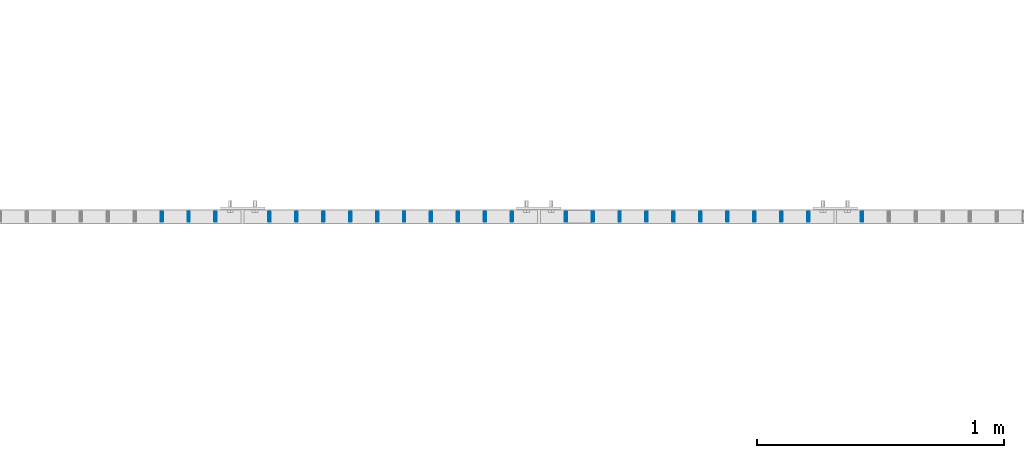
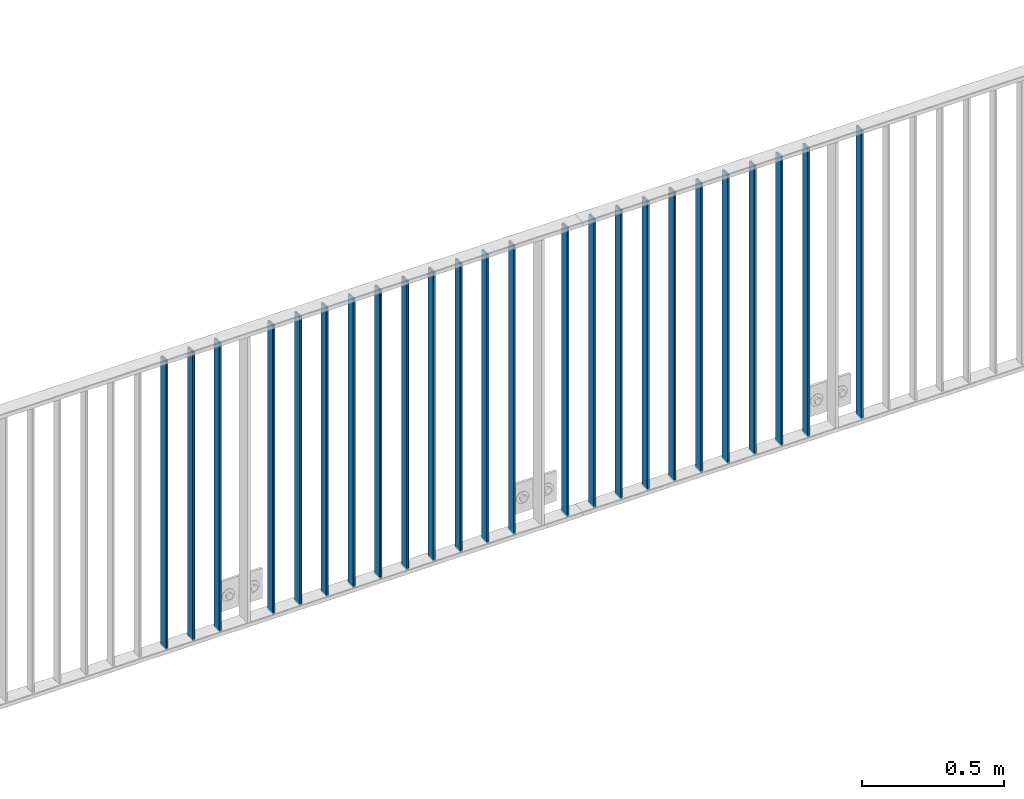
# One storey, part 6 of 156: 24 beams, 2 elements without a shape of their own.
"""IFC2X3 building model written with IfcOpenShell, lengths in millimetres."""

from ifc_helpers import new_model, si_unit, frame, origin_with_axes, origin_2d_with_axis, place, context, subcontext, project, spatial, hollow_rectangle, extrude, clip, halfspace, material, type_object, element, aggregate, save


model = new_model("IFC2X3")

# Units and contexts
model_context = context("Model", 3, precision=1e-05, world=origin_with_axes())
body_context = subcontext(model_context, "Body", "Model", "MODEL_VIEW")
ifc_project = project(units=[si_unit("LENGTHUNIT", "METRE", prefix="MILLI"), si_unit("AREAUNIT", "SQUARE_METRE"), si_unit("VOLUMEUNIT", "CUBIC_METRE"), si_unit("MASSUNIT", "GRAM", prefix="KILO"), si_unit("TIMEUNIT", "SECOND"), si_unit("PLANEANGLEUNIT", "RADIAN"), si_unit("SOLIDANGLEUNIT", "STERADIAN"), si_unit("THERMODYNAMICTEMPERATUREUNIT", "DEGREE_CELSIUS"), si_unit("LUMINOUSINTENSITYUNIT", "LUMEN")], contexts=[model_context])

# Site, building, storey
site_placement = place(None, origin_with_axes())
site = spatial("IfcSite", under=ifc_project, at=site_placement, CompositionType="ELEMENT")
building_placement = place(site_placement, origin_with_axes())
building = spatial("IfcBuilding", under=site, at=building_placement, Name="Undefined", CompositionType="ELEMENT")
storey_placement = place(building_placement, origin_with_axes())
storey = spatial("IfcBuildingStorey", under=building, at=storey_placement, Name="Undefined", CompositionType="ELEMENT", Elevation=0.0)

# Assembly, beams
assembly_1_placement = place(storey_placement, origin_with_axes())
assembly_1 = element("IfcElementAssembly", 1, at=assembly_1_placement, inside=storey, AssemblyPlace="NOTDEFINED", PredefinedType="RIGID_FRAME")
ifc_material = material(Name="STEEL/S235JR")
beam_type = type_object("IfcBeamType", Name="K40/10/1.5", PredefinedType="NOTDEFINED")
beam_1_placement = place(assembly_1_placement, frame((19109.089999999, 10879.9998088346, 3980.00000000003), z_axis=(0.0, 1.0, 0.0), x_axis=(0.0, 0.0, -1.0)))
beam_1 = element("IfcBeam", 2, at=beam_1_placement, type_object=beam_type, material=ifc_material, ObjectType="K40/10/1.5", context=body_context, shape_type="Clipping", body=[
    clip(clip(extrude(hollow_rectangle(XDim=10.0, YDim=40.0, WallThickness=1.5, InnerFilletRadius=1.5, OuterFilletRadius=3.0, at=origin_2d_with_axis()), frame((1237.00000000003, 0.0, 0.0), z_axis=(-1.0, 0.0, 0.0), x_axis=(0.0, -1.0, 0.0)), (0.0, 0.0, 1.0), 1244.0), halfspace(frame((1237.00000000003, 4.20486777192855, 47.2664069333041), z_axis=(1.0, 0.0, 0.0), x_axis=(0.0, -0.763991285051099, -0.645226562043109)), False)), halfspace(frame((-6.99999999997453, -3.90376720472705, 47.0154897941757), z_axis=(-1.0, 0.0, 0.0), x_axis=(0.0, 0.761952806119621, -0.647632551101653)), False)),
])
beam_2_placement = place(assembly_1_placement, frame((18890.899999999, 10879.9998088346, 3980.00000000003), z_axis=(0.0, 1.0, 0.0), x_axis=(0.0, 0.0, -1.0)))
beam_2 = element("IfcBeam", 3, at=beam_2_placement, type_object=beam_type, material=ifc_material, ObjectType="K40/10/1.5", context=body_context, shape_type="Clipping", body=[
    clip(clip(extrude(hollow_rectangle(XDim=10.0, YDim=40.0, WallThickness=1.5, InnerFilletRadius=1.5, OuterFilletRadius=3.0, at=origin_2d_with_axis()), frame((1237.00000000003, 0.0, 0.0), z_axis=(-1.0, 0.0, 0.0), x_axis=(0.0, -1.0, 0.0)), (0.0, 0.0, 1.0), 1244.0), halfspace(frame((1237.00000000003, 4.28697690345871, 47.3348312091512), z_axis=(1.0, 0.0, 0.0), x_axis=(0.0, -0.763991285051099, -0.645226562043109)), False)), halfspace(frame((-6.99999999997453, -4.08341515816574, 47.1651964219527), z_axis=(-1.0, 0.0, 0.0), x_axis=(0.0, 0.763991285051099, -0.645226562043109)), False)),
])
beam_3_placement = place(assembly_1_placement, frame((18781.809999999, 10879.9998088346, 3980.00000000003), z_axis=(0.0, 1.0, 0.0), x_axis=(0.0, 0.0, -1.0)))
beam_3 = element("IfcBeam", 4, at=beam_3_placement, type_object=beam_type, material=ifc_material, ObjectType="K40/10/1.5", context=body_context, shape_type="Clipping", body=[
    clip(clip(extrude(hollow_rectangle(XDim=10.0, YDim=40.0, WallThickness=1.5, InnerFilletRadius=1.5, OuterFilletRadius=3.0, at=origin_2d_with_axis()), frame((1237.00000000003, 0.0, 0.0), z_axis=(-1.0, 0.0, 0.0), x_axis=(0.0, -1.0, 0.0)), (0.0, 0.0, 1.0), 1244.0), halfspace(frame((1237.00000000003, 4.28697690345871, 47.3348312091512), z_axis=(1.0, 0.0, 0.0), x_axis=(0.0, -0.763991285051099, -0.645226562043109)), False)), halfspace(frame((-6.99999999997453, -4.08341515816574, 47.1651964219527), z_axis=(-1.0, 0.0, 0.0), x_axis=(0.0, 0.763991285051099, -0.645226562043109)), False)),
])
beam_4_placement = place(assembly_1_placement, frame((18672.719999999, 10879.9998088346, 3980.00000000003), z_axis=(0.0, 1.0, 0.0), x_axis=(0.0, 0.0, -1.0)))
beam_4 = element("IfcBeam", 5, at=beam_4_placement, type_object=beam_type, material=ifc_material, ObjectType="K40/10/1.5", context=body_context, shape_type="Clipping", body=[
    clip(clip(extrude(hollow_rectangle(XDim=10.0, YDim=40.0, WallThickness=1.5, InnerFilletRadius=1.5, OuterFilletRadius=3.0, at=origin_2d_with_axis()), frame((1237.00000000003, 0.0, 0.0), z_axis=(-1.0, 0.0, 0.0), x_axis=(0.0, -1.0, 0.0)), (0.0, 0.0, 1.0), 1244.0), halfspace(frame((1237.00000000003, 4.28697690345871, 47.3348312091512), z_axis=(1.0, 0.0, 0.0), x_axis=(0.0, -0.763991285051099, -0.645226562043109)), False)), halfspace(frame((-6.99999999997453, -4.08341515816574, 47.1651964219527), z_axis=(-1.0, 0.0, 0.0), x_axis=(0.0, 0.763991285051099, -0.645226562043109)), False)),
])
beam_5_placement = place(assembly_1_placement, frame((18563.629999999, 10879.9998088346, 3980.00000000003), z_axis=(0.0, 1.0, 0.0), x_axis=(0.0, 0.0, -1.0)))
beam_5 = element("IfcBeam", 6, at=beam_5_placement, type_object=beam_type, material=ifc_material, ObjectType="K40/10/1.5", context=body_context, shape_type="Clipping", body=[
    clip(clip(extrude(hollow_rectangle(XDim=10.0, YDim=40.0, WallThickness=1.5, InnerFilletRadius=1.5, OuterFilletRadius=3.0, at=origin_2d_with_axis()), frame((1237.00000000003, 0.0, 0.0), z_axis=(-1.0, 0.0, 0.0), x_axis=(0.0, -1.0, 0.0)), (0.0, 0.0, 1.0), 1244.0), halfspace(frame((1237.00000000003, 4.28697690345871, 47.3348312091512), z_axis=(1.0, 0.0, 0.0), x_axis=(0.0, -0.763991285051099, -0.645226562043109)), False)), halfspace(frame((-6.99999999997453, -4.08341515816574, 47.1651964219527), z_axis=(-1.0, 0.0, 0.0), x_axis=(0.0, 0.763991285051099, -0.645226562043109)), False)),
])
beam_6_placement = place(assembly_1_placement, frame((18454.539999999, 10879.9998088346, 3980.00000000003), z_axis=(0.0, 1.0, 0.0), x_axis=(0.0, 0.0, -1.0)))
beam_6 = element("IfcBeam", 7, at=beam_6_placement, type_object=beam_type, material=ifc_material, ObjectType="K40/10/1.5", context=body_context, shape_type="Clipping", body=[
    clip(clip(extrude(hollow_rectangle(XDim=10.0, YDim=40.0, WallThickness=1.5, InnerFilletRadius=1.5, OuterFilletRadius=3.0, at=origin_2d_with_axis()), frame((1237.00000000003, 0.0, 0.0), z_axis=(-1.0, 0.0, 0.0), x_axis=(0.0, -1.0, 0.0)), (0.0, 0.0, 1.0), 1244.0), halfspace(frame((1237.00000000003, 4.28697690345871, 47.3348312091512), z_axis=(1.0, 0.0, 0.0), x_axis=(0.0, -0.763991285051099, -0.645226562043109)), False)), halfspace(frame((-6.99999999997453, -4.08341515816574, 47.1651964219527), z_axis=(-1.0, 0.0, 0.0), x_axis=(0.0, 0.763991285051099, -0.645226562043109)), False)),
])
beam_7_placement = place(assembly_1_placement, frame((18345.449999999, 10879.9998088346, 3980.00000000003), z_axis=(0.0, 1.0, 0.0), x_axis=(0.0, 0.0, -1.0)))
beam_7 = element("IfcBeam", 8, at=beam_7_placement, type_object=beam_type, material=ifc_material, ObjectType="K40/10/1.5", context=body_context, shape_type="Clipping", body=[
    clip(clip(extrude(hollow_rectangle(XDim=10.0, YDim=40.0, WallThickness=1.5, InnerFilletRadius=1.5, OuterFilletRadius=3.0, at=origin_2d_with_axis()), frame((1237.00000000003, 0.0, 0.0), z_axis=(-1.0, 0.0, 0.0), x_axis=(0.0, -1.0, 0.0)), (0.0, 0.0, 1.0), 1244.0), halfspace(frame((1237.00000000003, 4.28697690345871, 47.3348312091512), z_axis=(1.0, 0.0, 0.0), x_axis=(0.0, -0.763991285051099, -0.645226562043109)), False)), halfspace(frame((-6.99999999997453, -4.08341515816574, 47.1651964219527), z_axis=(-1.0, 0.0, 0.0), x_axis=(0.0, 0.763991285051099, -0.645226562043109)), False)),
])
beam_8_placement = place(assembly_1_placement, frame((18236.359999999, 10879.9998088346, 3980.00000000003), z_axis=(0.0, 1.0, 0.0), x_axis=(0.0, 0.0, -1.0)))
beam_8 = element("IfcBeam", 9, at=beam_8_placement, type_object=beam_type, material=ifc_material, ObjectType="K40/10/1.5", context=body_context, shape_type="Clipping", body=[
    clip(clip(extrude(hollow_rectangle(XDim=10.0, YDim=40.0, WallThickness=1.5, InnerFilletRadius=1.5, OuterFilletRadius=3.0, at=origin_2d_with_axis()), frame((1237.00000000003, 0.0, 0.0), z_axis=(-1.0, 0.0, 0.0), x_axis=(0.0, -1.0, 0.0)), (0.0, 0.0, 1.0), 1244.0), halfspace(frame((1237.00000000003, 4.28697690345871, 47.3348312091512), z_axis=(1.0, 0.0, 0.0), x_axis=(0.0, -0.763991285051099, -0.645226562043109)), False)), halfspace(frame((-6.99999999997453, -4.08341515816574, 47.1651964219527), z_axis=(-1.0, 0.0, 0.0), x_axis=(0.0, 0.763991285051099, -0.645226562043109)), False)),
])
beam_9_placement = place(assembly_1_placement, frame((18127.269999999, 10879.9998088346, 3980.00000000003), z_axis=(0.0, 1.0, 0.0), x_axis=(0.0, 0.0, -1.0)))
beam_9 = element("IfcBeam", 10, at=beam_9_placement, type_object=beam_type, material=ifc_material, ObjectType="K40/10/1.5", context=body_context, shape_type="Clipping", body=[
    clip(clip(extrude(hollow_rectangle(XDim=10.0, YDim=40.0, WallThickness=1.5, InnerFilletRadius=1.5, OuterFilletRadius=3.0, at=origin_2d_with_axis()), frame((1237.00000000003, 0.0, 0.0), z_axis=(-1.0, 0.0, 0.0), x_axis=(0.0, -1.0, 0.0)), (0.0, 0.0, 1.0), 1244.0), halfspace(frame((1237.00000000003, 4.28697690345871, 47.3348312091512), z_axis=(1.0, 0.0, 0.0), x_axis=(0.0, -0.763991285051099, -0.645226562043109)), False)), halfspace(frame((-6.99999999997453, -4.08341515816574, 47.1651964219527), z_axis=(-1.0, 0.0, 0.0), x_axis=(0.0, 0.763991285051099, -0.645226562043109)), False)),
])
beam_10_placement = place(assembly_1_placement, frame((18018.179999999, 10879.9998088346, 3980.00000000003), z_axis=(0.0, 1.0, 0.0), x_axis=(0.0, 0.0, -1.0)))
beam_10 = element("IfcBeam", 11, at=beam_10_placement, type_object=beam_type, material=ifc_material, ObjectType="K40/10/1.5", context=body_context, shape_type="Clipping", body=[
    clip(clip(extrude(hollow_rectangle(XDim=10.0, YDim=40.0, WallThickness=1.5, InnerFilletRadius=1.5, OuterFilletRadius=3.0, at=origin_2d_with_axis()), frame((1237.00000000003, 0.0, 0.0), z_axis=(-1.0, 0.0, 0.0), x_axis=(0.0, -1.0, 0.0)), (0.0, 0.0, 1.0), 1244.0), halfspace(frame((1237.00000000003, 4.28697690345871, 47.3348312091512), z_axis=(1.0, 0.0, 0.0), x_axis=(0.0, -0.763991285051099, -0.645226562043109)), False)), halfspace(frame((-6.99999999997453, -4.08341515816574, 47.1651964219527), z_axis=(-1.0, 0.0, 0.0), x_axis=(0.0, 0.763991285051099, -0.645226562043109)), False)),
])
aggregate(assembly_1, [beam_1, beam_2, beam_3, beam_4, beam_5, beam_6, beam_7, beam_8, beam_9, beam_10])

assembly_2_placement = place(storey_placement, origin_with_axes())
assembly_2 = element("IfcElementAssembly", 12, at=assembly_2_placement, inside=storey, AssemblyPlace="NOTDEFINED", PredefinedType="RIGID_FRAME")
beam_11_placement = place(assembly_2_placement, frame((17909.089999999, 10879.9998088346, 3980.00000000003), z_axis=(0.0, 1.0, 0.0), x_axis=(0.0, 0.0, -1.0)))
beam_11 = element("IfcBeam", 13, at=beam_11_placement, type_object=beam_type, material=ifc_material, ObjectType="K40/10/1.5", context=body_context, shape_type="Clipping", body=[
    clip(clip(extrude(hollow_rectangle(XDim=10.0, YDim=40.0, WallThickness=1.5, InnerFilletRadius=1.5, OuterFilletRadius=3.0, at=origin_2d_with_axis()), frame((1237.00000000003, 0.0, 0.0), z_axis=(-1.0, 0.0, 0.0), x_axis=(0.0, -1.0, 0.0)), (0.0, 0.0, 1.0), 1244.0), halfspace(frame((1237.00000000003, 1.80362172154128, 45.2653685592795), z_axis=(1.0, 0.0, 0.0), x_axis=(0.0, -0.737586551668085, -0.675252603696115)), False)), halfspace(frame((-6.99999999997453, -0.5315859633738, 44.2053387614833), z_axis=(-1.0, 0.0, 0.0), x_axis=(0.0, 0.722377441111346, -0.691498975106561)), False)),
])
beam_12_placement = place(assembly_2_placement, frame((17690.899999999, 10879.9998088346, 3980.00000000003), z_axis=(0.0, 1.0, 0.0), x_axis=(0.0, 0.0, -1.0)))
beam_12 = element("IfcBeam", 14, at=beam_12_placement, type_object=beam_type, material=ifc_material, ObjectType="K40/10/1.5", context=body_context, shape_type="Clipping", body=[
    clip(clip(extrude(hollow_rectangle(XDim=10.0, YDim=40.0, WallThickness=1.5, InnerFilletRadius=1.5, OuterFilletRadius=3.0, at=origin_2d_with_axis()), frame((1237.00000000003, 0.0, 0.0), z_axis=(-1.0, 0.0, 0.0), x_axis=(0.0, -1.0, 0.0)), (0.0, 0.0, 1.0), 1244.0), halfspace(frame((1237.00000000003, 3.90376720472705, 47.0154897941684), z_axis=(1.0, 0.0, 0.0), x_axis=(0.0, -0.761952806119621, -0.647632551101653)), False)), halfspace(frame((-6.99999999997453, -3.24498419219526, 46.4665039507308), z_axis=(-1.0, 0.0, 0.0), x_axis=(0.0, 0.75441426312288, -0.656398598106944)), False)),
])
beam_13_placement = place(assembly_2_placement, frame((17581.809999999, 10879.9998088346, 3980.00000000003), z_axis=(0.0, 1.0, 0.0), x_axis=(0.0, 0.0, -1.0)))
beam_13 = element("IfcBeam", 15, at=beam_13_placement, type_object=beam_type, material=ifc_material, ObjectType="K40/10/1.5", context=body_context, shape_type="Clipping", body=[
    clip(clip(extrude(hollow_rectangle(XDim=10.0, YDim=40.0, WallThickness=1.5, InnerFilletRadius=1.5, OuterFilletRadius=3.0, at=origin_2d_with_axis()), frame((1237.00000000003, 0.0, 0.0), z_axis=(-1.0, 0.0, 0.0), x_axis=(0.0, -1.0, 0.0)), (0.0, 0.0, 1.0), 1244.0), halfspace(frame((1237.00000000003, 3.90376720472705, 47.0154897941684), z_axis=(1.0, 0.0, 0.0), x_axis=(0.0, -0.761952806119621, -0.647632551101653)), False)), halfspace(frame((-6.99999999997453, -3.24498419219526, 46.4665039507308), z_axis=(-1.0, 0.0, 0.0), x_axis=(0.0, 0.75441426312288, -0.656398598106944)), False)),
])
beam_14_placement = place(assembly_2_placement, frame((17472.719999999, 10879.9998088346, 3980.00000000003), z_axis=(0.0, 1.0, 0.0), x_axis=(0.0, 0.0, -1.0)))
beam_14 = element("IfcBeam", 16, at=beam_14_placement, type_object=beam_type, material=ifc_material, ObjectType="K40/10/1.5", context=body_context, shape_type="Clipping", body=[
    clip(clip(extrude(hollow_rectangle(XDim=10.0, YDim=40.0, WallThickness=1.5, InnerFilletRadius=1.5, OuterFilletRadius=3.0, at=origin_2d_with_axis()), frame((1237.00000000003, 0.0, 0.0), z_axis=(-1.0, 0.0, 0.0), x_axis=(0.0, -1.0, 0.0)), (0.0, 0.0, 1.0), 1244.0), halfspace(frame((1237.00000000003, 3.90376720472705, 47.0154897941684), z_axis=(1.0, 0.0, 0.0), x_axis=(0.0, -0.761952806119621, -0.647632551101653)), False)), halfspace(frame((-6.99999999997453, -3.24498419219526, 46.4665039507308), z_axis=(-1.0, 0.0, 0.0), x_axis=(0.0, 0.75441426312288, -0.656398598106944)), False)),
])
beam_15_placement = place(assembly_2_placement, frame((17363.629999999, 10879.9998088346, 3980.00000000003), z_axis=(0.0, 1.0, 0.0), x_axis=(0.0, 0.0, -1.0)))
beam_15 = element("IfcBeam", 17, at=beam_15_placement, type_object=beam_type, material=ifc_material, ObjectType="K40/10/1.5", context=body_context, shape_type="Clipping", body=[
    clip(clip(extrude(hollow_rectangle(XDim=10.0, YDim=40.0, WallThickness=1.5, InnerFilletRadius=1.5, OuterFilletRadius=3.0, at=origin_2d_with_axis()), frame((1237.00000000003, 0.0, 0.0), z_axis=(-1.0, 0.0, 0.0), x_axis=(0.0, -1.0, 0.0)), (0.0, 0.0, 1.0), 1244.0), halfspace(frame((1237.00000000003, 3.90376720472705, 47.0154897941684), z_axis=(1.0, 0.0, 0.0), x_axis=(0.0, -0.761952806119621, -0.647632551101653)), False)), halfspace(frame((-6.99999999997453, -3.24498419219526, 46.4665039507308), z_axis=(-1.0, 0.0, 0.0), x_axis=(0.0, 0.75441426312288, -0.656398598106944)), False)),
])
beam_16_placement = place(assembly_2_placement, frame((17254.539999999, 10879.9998088346, 3980.00000000003), z_axis=(0.0, 1.0, 0.0), x_axis=(0.0, 0.0, -1.0)))
beam_16 = element("IfcBeam", 18, at=beam_16_placement, type_object=beam_type, material=ifc_material, ObjectType="K40/10/1.5", context=body_context, shape_type="Clipping", body=[
    clip(clip(extrude(hollow_rectangle(XDim=10.0, YDim=40.0, WallThickness=1.5, InnerFilletRadius=1.5, OuterFilletRadius=3.0, at=origin_2d_with_axis()), frame((1237.00000000003, 0.0, 0.0), z_axis=(-1.0, 0.0, 0.0), x_axis=(0.0, -1.0, 0.0)), (0.0, 0.0, 1.0), 1244.0), halfspace(frame((1237.00000000003, 3.90376720472705, 47.0154897941684), z_axis=(1.0, 0.0, 0.0), x_axis=(0.0, -0.761952806119621, -0.647632551101653)), False)), halfspace(frame((-6.99999999997453, -3.24498419219526, 46.4665039507308), z_axis=(-1.0, 0.0, 0.0), x_axis=(0.0, 0.75441426312288, -0.656398598106944)), False)),
])
beam_17_placement = place(assembly_2_placement, frame((17145.449999999, 10879.9998088346, 3980.00000000003), z_axis=(0.0, 1.0, 0.0), x_axis=(0.0, 0.0, -1.0)))
beam_17 = element("IfcBeam", 19, at=beam_17_placement, type_object=beam_type, material=ifc_material, ObjectType="K40/10/1.5", context=body_context, shape_type="Clipping", body=[
    clip(clip(extrude(hollow_rectangle(XDim=10.0, YDim=40.0, WallThickness=1.5, InnerFilletRadius=1.5, OuterFilletRadius=3.0, at=origin_2d_with_axis()), frame((1237.00000000003, 0.0, 0.0), z_axis=(-1.0, 0.0, 0.0), x_axis=(0.0, -1.0, 0.0)), (0.0, 0.0, 1.0), 1244.0), halfspace(frame((1237.00000000003, 3.90376720472705, 47.0154897941684), z_axis=(1.0, 0.0, 0.0), x_axis=(0.0, -0.761952806119621, -0.647632551101653)), False)), halfspace(frame((-6.99999999997453, -3.24498419219526, 46.4665039507308), z_axis=(-1.0, 0.0, 0.0), x_axis=(0.0, 0.75441426312288, -0.656398598106944)), False)),
])
beam_18_placement = place(assembly_2_placement, frame((17036.359999999, 10879.9998088346, 3980.00000000003), z_axis=(0.0, 1.0, 0.0), x_axis=(0.0, 0.0, -1.0)))
beam_18 = element("IfcBeam", 20, at=beam_18_placement, type_object=beam_type, material=ifc_material, ObjectType="K40/10/1.5", context=body_context, shape_type="Clipping", body=[
    clip(clip(extrude(hollow_rectangle(XDim=10.0, YDim=40.0, WallThickness=1.5, InnerFilletRadius=1.5, OuterFilletRadius=3.0, at=origin_2d_with_axis()), frame((1237.00000000003, 0.0, 0.0), z_axis=(-1.0, 0.0, 0.0), x_axis=(0.0, -1.0, 0.0)), (0.0, 0.0, 1.0), 1244.0), halfspace(frame((1237.00000000003, 3.90376720472705, 47.0154897941684), z_axis=(1.0, 0.0, 0.0), x_axis=(0.0, -0.761952806119621, -0.647632551101653)), False)), halfspace(frame((-6.99999999997453, -3.24498419219526, 46.4665039507308), z_axis=(-1.0, 0.0, 0.0), x_axis=(0.0, 0.75441426312288, -0.656398598106944)), False)),
])
beam_19_placement = place(assembly_2_placement, frame((16927.269999999, 10879.9998088346, 3980.00000000003), z_axis=(0.0, 1.0, 0.0), x_axis=(0.0, 0.0, -1.0)))
beam_19 = element("IfcBeam", 21, at=beam_19_placement, type_object=beam_type, material=ifc_material, ObjectType="K40/10/1.5", context=body_context, shape_type="Clipping", body=[
    clip(clip(extrude(hollow_rectangle(XDim=10.0, YDim=40.0, WallThickness=1.5, InnerFilletRadius=1.5, OuterFilletRadius=3.0, at=origin_2d_with_axis()), frame((1237.00000000003, 0.0, 0.0), z_axis=(-1.0, 0.0, 0.0), x_axis=(0.0, -1.0, 0.0)), (0.0, 0.0, 1.0), 1244.0), halfspace(frame((1237.00000000003, 3.90376720472705, 47.0154897941684), z_axis=(1.0, 0.0, 0.0), x_axis=(0.0, -0.761952806119621, -0.647632551101653)), False)), halfspace(frame((-6.99999999997453, -3.24498419219526, 46.4665039507308), z_axis=(-1.0, 0.0, 0.0), x_axis=(0.0, 0.75441426312288, -0.656398598106944)), False)),
])
beam_20_placement = place(assembly_2_placement, frame((16818.179999999, 10879.9998088346, 3980.00000000003), z_axis=(0.0, 1.0, 0.0), x_axis=(0.0, 0.0, -1.0)))
beam_20 = element("IfcBeam", 22, at=beam_20_placement, type_object=beam_type, material=ifc_material, ObjectType="K40/10/1.5", context=body_context, shape_type="Clipping", body=[
    clip(clip(extrude(hollow_rectangle(XDim=10.0, YDim=40.0, WallThickness=1.5, InnerFilletRadius=1.5, OuterFilletRadius=3.0, at=origin_2d_with_axis()), frame((1237.00000000003, 0.0, 0.0), z_axis=(-1.0, 0.0, 0.0), x_axis=(0.0, -1.0, 0.0)), (0.0, 0.0, 1.0), 1244.0), halfspace(frame((1237.00000000003, 3.90376720472705, 47.0154897941684), z_axis=(1.0, 0.0, 0.0), x_axis=(0.0, -0.761952806119621, -0.647632551101653)), False)), halfspace(frame((-6.99999999997453, -3.24498419219526, 46.4665039507308), z_axis=(-1.0, 0.0, 0.0), x_axis=(0.0, 0.75441426312288, -0.656398598106944)), False)),
])
beam_21_placement = place(assembly_2_placement, frame((16709.089999999, 10879.9998088346, 3980.00000000003), z_axis=(0.0, 1.0, 0.0), x_axis=(0.0, 0.0, -1.0)))
beam_21 = element("IfcBeam", 23, at=beam_21_placement, type_object=beam_type, material=ifc_material, ObjectType="K40/10/1.5", context=body_context, shape_type="Clipping", body=[
    clip(clip(extrude(hollow_rectangle(XDim=10.0, YDim=40.0, WallThickness=1.5, InnerFilletRadius=1.5, OuterFilletRadius=3.0, at=origin_2d_with_axis()), frame((1237.00000000003, 0.0, 0.0), z_axis=(-1.0, 0.0, 0.0), x_axis=(0.0, -1.0, 0.0)), (0.0, 0.0, 1.0), 1244.0), halfspace(frame((1237.00000000003, 3.63803898150218, 46.7940496082883), z_axis=(1.0, 0.0, 0.0), x_axis=(0.0, -0.758923924280425, -0.65117929724063)), False)), halfspace(frame((-6.99999999997453, -2.66359292875859, 45.9820112315028), z_axis=(-1.0, 0.0, 0.0), x_axis=(0.0, 0.747680594279002, -0.664058528247773)), False)),
])
beam_22_placement = place(assembly_2_placement, frame((16490.899999999, 10879.9998088346, 3980.00000000003), z_axis=(0.0, 1.0, 0.0), x_axis=(0.0, 0.0, -1.0)))
beam_22 = element("IfcBeam", 24, at=beam_22_placement, type_object=beam_type, material=ifc_material, ObjectType="K40/10/1.5", context=body_context, shape_type="Clipping", body=[
    clip(clip(extrude(hollow_rectangle(XDim=10.0, YDim=40.0, WallThickness=1.5, InnerFilletRadius=1.5, OuterFilletRadius=3.0, at=origin_2d_with_axis()), frame((1237.00000000003, 0.0, 0.0), z_axis=(-1.0, 0.0, 0.0), x_axis=(0.0, -1.0, 0.0)), (0.0, 0.0, 1.0), 1244.0), halfspace(frame((1237.00000000003, 3.90376720472705, 47.0154897941684), z_axis=(1.0, 0.0, 0.0), x_axis=(0.0, -0.761952806119621, -0.647632551101653)), False)), halfspace(frame((-6.99999999997453, -3.24498419219526, 46.4665039507308), z_axis=(-1.0, 0.0, 0.0), x_axis=(0.0, 0.75441426312288, -0.656398598106944)), False)),
])
beam_23_placement = place(assembly_2_placement, frame((16381.809999999, 10879.9998088346, 3980.00000000003), z_axis=(0.0, 1.0, 0.0), x_axis=(0.0, 0.0, -1.0)))
beam_23 = element("IfcBeam", 25, at=beam_23_placement, type_object=beam_type, material=ifc_material, ObjectType="K40/10/1.5", context=body_context, shape_type="Clipping", body=[
    clip(clip(extrude(hollow_rectangle(XDim=10.0, YDim=40.0, WallThickness=1.5, InnerFilletRadius=1.5, OuterFilletRadius=3.0, at=origin_2d_with_axis()), frame((1237.00000000003, 0.0, 0.0), z_axis=(-1.0, 0.0, 0.0), x_axis=(0.0, -1.0, 0.0)), (0.0, 0.0, 1.0), 1244.0), halfspace(frame((1237.00000000003, 3.90376720472705, 47.0154897941684), z_axis=(1.0, 0.0, 0.0), x_axis=(0.0, -0.761952806119621, -0.647632551101653)), False)), halfspace(frame((-6.99999999997453, -3.24498419219526, 46.4665039507308), z_axis=(-1.0, 0.0, 0.0), x_axis=(0.0, 0.75441426312288, -0.656398598106944)), False)),
])
beam_24_placement = place(assembly_2_placement, frame((16272.719999999, 10879.9998088346, 3980.00000000003), z_axis=(0.0, 1.0, 0.0), x_axis=(0.0, 0.0, -1.0)))
beam_24 = element("IfcBeam", 26, at=beam_24_placement, type_object=beam_type, material=ifc_material, ObjectType="K40/10/1.5", context=body_context, shape_type="Clipping", body=[
    clip(clip(extrude(hollow_rectangle(XDim=10.0, YDim=40.0, WallThickness=1.5, InnerFilletRadius=1.5, OuterFilletRadius=3.0, at=origin_2d_with_axis()), frame((1237.00000000003, 0.0, 0.0), z_axis=(-1.0, 0.0, 0.0), x_axis=(0.0, -1.0, 0.0)), (0.0, 0.0, 1.0), 1244.0), halfspace(frame((1237.00000000003, 3.90376720472705, 47.0154897941684), z_axis=(1.0, 0.0, 0.0), x_axis=(0.0, -0.761952806119621, -0.647632551101653)), False)), halfspace(frame((-6.99999999997453, -3.24498419219526, 46.4665039507308), z_axis=(-1.0, 0.0, 0.0), x_axis=(0.0, 0.75441426312288, -0.656398598106944)), False)),
])
aggregate(assembly_2, [beam_11, beam_12, beam_13, beam_14, beam_15, beam_16, beam_17, beam_18, beam_19, beam_20, beam_21, beam_22, beam_23, beam_24])

save(model, "model.ifc")
